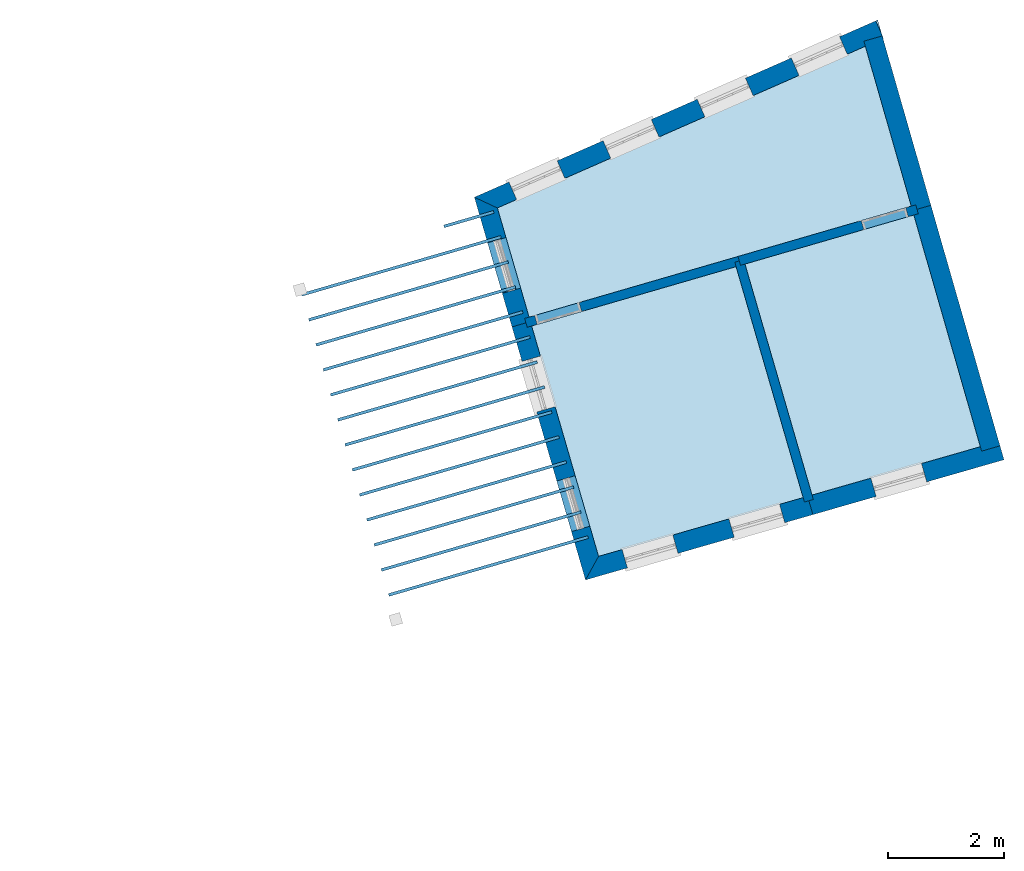
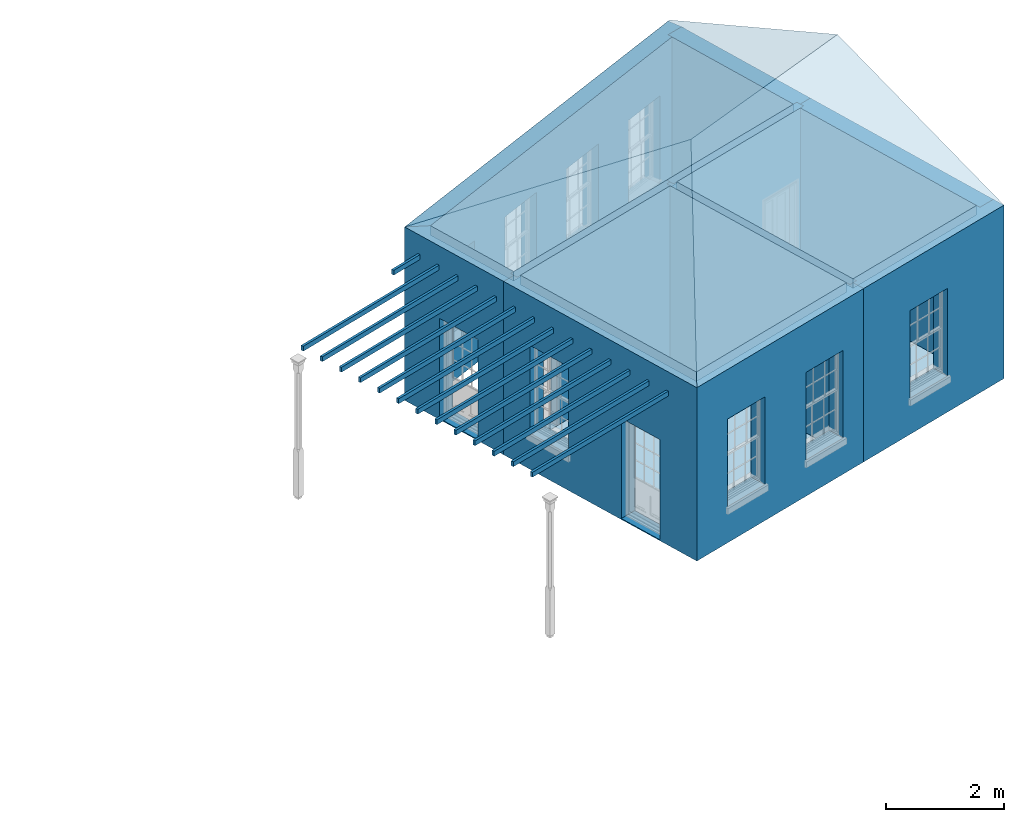
# One storey, part 1 of 10: 19 slabs, 10 walls, 1 roof, 12 openings.
"""IFC2X3 building model written with IfcOpenShell, lengths in metres."""

from ifc_helpers import new_model, si_unit, frame, origin, place, context, subcontext, project, spatial, polyline, outline, extrude, faceted_brep, material, layer, layer_set, layer_usage, element, save


model = new_model("IFC2X3")

# Units and contexts
model_context = context("Model", 3, world=origin())
body_context = subcontext(model_context, "Body", "Model", "MODEL_VIEW")
ifc_project = project(units=[si_unit("PLANEANGLEUNIT", "RADIAN"), si_unit("MASSUNIT", "GRAM", prefix="KILO"), si_unit("FORCEUNIT", "NEWTON", prefix="KILO"), si_unit("LENGTHUNIT", "METRE")], contexts=[model_context])

# Site, building, storey
site_placement = place(None, origin())
site = spatial("IfcSite", under=ifc_project, at=site_placement, CompositionType="ELEMENT")
building_placement = place(None, origin())
building = spatial("IfcBuilding", under=site, at=building_placement, Name="Building plot-15", CompositionType="ELEMENT")
storey_placement = place(None, frame((0.0, 0.0, 11.05)))
storey = spatial("IfcBuildingStorey", under=building, at=storey_placement, Name="Floor 2", CompositionType="ELEMENT", Elevation=11.05)

# Slabs
slab_1_placement = place(storey_placement, frame((0.0, 0.0, 3.4)))
element("IfcSlab", 1, at=slab_1_placement, inside=storey, Name="Slab", ObjectType="Slab", PredefinedType="FLOOR", context=body_context, shape_type="SweptSolid", body=[
    extrude(outline(polyline([(93.1259419481481, 56.4653028026416), (89.5934562606152, 55.4394989093001), (90.7492750995838, 51.4592902821545), (94.2845837491432, 52.4747060086671), (93.1259419481481, 56.4653028026416)])), origin(), (0.0, 0.0, 1.0), 0.2),
])
slab_2_placement = place(storey_placement, frame((0.0, 0.0, 3.1)))
element("IfcSlab", 2, at=slab_2_placement, inside=storey, Name="Slab", ObjectType="Slab", PredefinedType="FLOOR", context=body_context, shape_type="SweptSolid", body=[
    extrude(outline(polyline([(90.5761730497304, 51.7685183951452), (90.5622294870498, 51.816534820041), (87.1161724198014, 50.8158290652416), (87.130115982482, 50.7678126403459), (90.5761730497304, 51.7685183951452)])), origin(), (0.0, 0.0, 1.0), 0.1),
])
slab_3_placement = place(storey_placement, frame((0.0, 0.0, 3.1)))
element("IfcSlab", 3, at=slab_3_placement, inside=storey, Name="Slab", ObjectType="Slab", PredefinedType="FLOOR", context=body_context, shape_type="SweptSolid", body=[
    extrude(outline(polyline([(90.450680985605, 52.2006662192073), (90.4367374229244, 52.248682644103), (86.990680355676, 51.2479768893037), (87.0046239183566, 51.1999604644079), (90.450680985605, 52.2006662192073)])), origin(), (0.0, 0.0, 1.0), 0.1),
])
slab_4_placement = place(storey_placement, frame((0.0, 0.0, 3.1)))
element("IfcSlab", 4, at=slab_4_placement, inside=storey, Name="Slab", ObjectType="Slab", PredefinedType="FLOOR", context=body_context, shape_type="SweptSolid", body=[
    extrude(outline(polyline([(90.3251889214796, 52.6328140432693), (90.311245358799, 52.6808304681651), (86.8651882915506, 51.6801247133657), (86.8791318542312, 51.6321082884699), (90.3251889214796, 52.6328140432693)])), origin(), (0.0, 0.0, 1.0), 0.1),
])
slab_5_placement = place(storey_placement, frame((0.0, 0.0, 3.1)))
element("IfcSlab", 5, at=slab_5_placement, inside=storey, Name="Slab", ObjectType="Slab", PredefinedType="FLOOR", context=body_context, shape_type="SweptSolid", body=[
    extrude(outline(polyline([(90.1996968573542, 53.0649618673313), (90.1857532946736, 53.1129782922271), (86.7396962274252, 52.1122725374277), (86.7536397901058, 52.064256112532), (90.1996968573542, 53.0649618673313)])), origin(), (0.0, 0.0, 1.0), 0.1),
])
slab_6_placement = place(storey_placement, frame((0.0, 0.0, 3.1)))
element("IfcSlab", 6, at=slab_6_placement, inside=storey, Name="Slab", ObjectType="Slab", PredefinedType="FLOOR", context=body_context, shape_type="SweptSolid", body=[
    extrude(outline(polyline([(90.0742047932288, 53.4971096913934), (90.0602612305482, 53.5451261162891), (86.6142041632998, 52.5444203614898), (86.6281477259804, 52.496403936594), (90.0742047932288, 53.4971096913934)])), origin(), (0.0, 0.0, 1.0), 0.1),
])
slab_7_placement = place(storey_placement, frame((0.0, 0.0, 3.1)))
element("IfcSlab", 7, at=slab_7_placement, inside=storey, Name="Slab", ObjectType="Slab", PredefinedType="FLOOR", context=body_context, shape_type="SweptSolid", body=[
    extrude(outline(polyline([(89.9487127291034, 53.9292575154554), (89.9347691664228, 53.9772739403512), (86.4887120991744, 52.9765681855518), (86.502655661855, 52.928551760656), (89.9487127291034, 53.9292575154554)])), origin(), (0.0, 0.0, 1.0), 0.1),
])
slab_8_placement = place(storey_placement, frame((0.0, 0.0, 3.1)))
element("IfcSlab", 8, at=slab_8_placement, inside=storey, Name="Slab", ObjectType="Slab", PredefinedType="FLOOR", context=body_context, shape_type="SweptSolid", body=[
    extrude(outline(polyline([(89.823220664978, 54.3614053395174), (89.8092771022974, 54.4094217644132), (86.363220035049, 53.4087160096138), (86.3771635977296, 53.360699584718), (89.823220664978, 54.3614053395174)])), origin(), (0.0, 0.0, 1.0), 0.1),
])
slab_9_placement = place(storey_placement, frame((0.0, 0.0, 3.1)))
element("IfcSlab", 9, at=slab_9_placement, inside=storey, Name="Slab", ObjectType="Slab", PredefinedType="FLOOR", context=body_context, shape_type="SweptSolid", body=[
    extrude(outline(polyline([(89.6977286008526, 54.7935531635795), (89.683785038172, 54.8415695884752), (86.2377279709236, 53.8408638336759), (86.2516715336042, 53.7928474087801), (89.6977286008526, 54.7935531635795)])), origin(), (0.0, 0.0, 1.0), 0.1),
])
slab_10_placement = place(storey_placement, frame((0.0, 0.0, 3.1)))
element("IfcSlab", 10, at=slab_10_placement, inside=storey, Name="Slab", ObjectType="Slab", PredefinedType="FLOOR", context=body_context, shape_type="SweptSolid", body=[
    extrude(outline(polyline([(89.5722365367273, 55.2257009876415), (89.5582929740467, 55.2737174125373), (86.1122359067982, 54.2730116577379), (86.1261794694788, 54.2249952328421), (89.5722365367273, 55.2257009876415)])), origin(), (0.0, 0.0, 1.0), 0.1),
])
slab_11_placement = place(storey_placement, frame((0.0, 0.0, 3.1)))
element("IfcSlab", 11, at=slab_11_placement, inside=storey, Name="Slab", ObjectType="Slab", PredefinedType="FLOOR", context=body_context, shape_type="SweptSolid", body=[
    extrude(outline(polyline([(89.4467444726019, 55.6578488117035), (89.4328009099213, 55.7058652365993), (85.9867438426728, 54.7051594817999), (86.0006874053534, 54.6571430569041), (89.4467444726019, 55.6578488117035)])), origin(), (0.0, 0.0, 1.0), 0.1),
])
slab_12_placement = place(storey_placement, frame((0.0, 0.0, 3.1)))
element("IfcSlab", 12, at=slab_12_placement, inside=storey, Name="Slab", ObjectType="Slab", PredefinedType="FLOOR", context=body_context, shape_type="SweptSolid", body=[
    extrude(outline(polyline([(89.3212524084765, 56.0899966357656), (89.3073088457959, 56.1380130606613), (85.8612517785474, 55.1373073058619), (85.875195341228, 55.0892908809662), (89.3212524084765, 56.0899966357656)])), origin(), (0.0, 0.0, 1.0), 0.1),
])
slab_13_placement = place(storey_placement, frame((0.0, 0.0, 3.1)))
element("IfcSlab", 13, at=slab_13_placement, inside=storey, Name="Slab", ObjectType="Slab", PredefinedType="FLOOR", context=body_context, shape_type="SweptSolid", body=[
    extrude(outline(polyline([(89.1957603443511, 56.5221444598276), (89.1818167816705, 56.5701608847234), (85.735759714422, 55.569455129924), (85.7497032771026, 55.5214387050282), (89.1957603443511, 56.5221444598276)])), origin(), (0.0, 0.0, 1.0), 0.1),
])
slab_14_placement = place(storey_placement, frame((0.0, 0.0, 3.1)))
element("IfcSlab", 14, at=slab_14_placement, inside=storey, Name="Slab", ObjectType="Slab", PredefinedType="FLOOR", context=body_context, shape_type="SweptSolid", body=[
    extrude(outline(polyline([(89.0702682802257, 56.9542922838896), (89.0563247175451, 57.0023087087854), (85.6102676502966, 56.001602953986), (85.6242112129772, 55.9535865290902), (89.0702682802257, 56.9542922838896)])), origin(), (0.0, 0.0, 1.0), 0.1),
])
slab_15_placement = place(storey_placement, frame((0.0, 0.0, 3.1)))
element("IfcSlab", 15, at=slab_15_placement, inside=storey, Name="Slab", ObjectType="Slab", PredefinedType="FLOOR", context=body_context, shape_type="SweptSolid", body=[
    extrude(outline(polyline([(88.9447762161003, 57.3864401079516), (88.9308326534197, 57.4344565328474), (88.0709453138879, 57.1847525400358), (88.0848888765685, 57.13673611514), (88.9447762161003, 57.3864401079516)])), origin(), (0.0, 0.0, 1.0), 0.1),
])
slab_16_placement = place(storey_placement, frame((0.0, 0.0, 3.4)))
element("IfcSlab", 16, at=slab_16_placement, inside=storey, Name="Slab", ObjectType="Slab", PredefinedType="FLOOR", context=body_context, shape_type="SweptSolid", body=[
    extrude(outline(polyline([(96.1971993792139, 57.357169920847), (93.2795945079686, 56.5099222032643), (94.4383668549021, 52.5188757826638), (97.3469163931548, 53.3542729813922), (96.1971993792139, 57.357169920847)])), origin(), (0.0, 0.0, 1.0), 0.2),
])
slab_17_placement = place(storey_placement, frame((0.0, 0.0, 3.4)))
element("IfcSlab", 17, at=slab_17_placement, inside=storey, Name="Slab", ObjectType="Slab", PredefinedType="FLOOR", context=body_context, shape_type="SweptSolid", body=[
    extrude(outline(polyline([(89.0011789339124, 57.4790809319541), (89.5488368600373, 55.5931514689665), (96.1530295994764, 57.5109530465934), (95.3596374797679, 60.2732561605415), (89.0011789339124, 57.4790809319541)])), origin(), (0.0, 0.0, 1.0), 0.2),
])
slab_18_placement = place(storey_placement, origin())
element("IfcSlab", 18, at=slab_18_placement, inside=storey, Name="Slab", ObjectType="Slab", PredefinedType="FLOOR", context=body_context, shape_type="SweptSolid", body=[
    extrude(outline(polyline([(93.1259419481481, 56.4653028026416), (89.5934562606152, 55.4394989093001), (90.7492750995838, 51.4592902821545), (94.2845837491432, 52.4747060086671), (93.1259419481481, 56.4653028026416)])), origin(), (0.0, 0.0, 1.0), 0.02),
])
slab_19_placement = place(storey_placement, origin())
element("IfcSlab", 19, at=slab_19_placement, inside=storey, Name="Slab", ObjectType="Slab", PredefinedType="FLOOR", context=body_context, shape_type="SweptSolid", body=[
    extrude(outline(polyline([(96.1971993792139, 57.357169920847), (93.2795945079686, 56.5099222032643), (94.4383668549021, 52.5188757826638), (97.3469163931548, 53.3542729813922), (96.1971993792139, 57.357169920847)])), origin(), (0.0, 0.0, 1.0), 0.02),
])

# Wall, openings
ifc_material_1 = material(Name="Masonry")
ifc_layer_1 = layer(ifc_material_1, 0.33, ventilated=False)
ifc_layer_set_1 = layer_set([ifc_layer_1], Name="My Wall")
ifc_layer_usage_1 = layer_usage(ifc_layer_set_1, "AXIS2", "NEGATIVE", 0.08)
wall_1_placement = place(storey_placement, origin())
wall_1 = element("IfcWallStandardCase", 20, at=wall_1_placement, inside=storey, material=ifc_layer_usage_1, Name="exterior", context=body_context, shape_type="SweptSolid", body=[
    extrude(outline(polyline([(95.6723187451732, 60.4106615143609), (95.5395561949644, 60.7127775603797), (88.6036069877965, 57.6648285454347), (89.0011789339124, 57.4790809319541), (95.6723187451732, 60.4106615143609)])), origin(), (0.0, 0.0, 1.0), 3.6),
])
opening_1_placement = place(storey_placement, frame((0.0, 0.0, 0.75)))
element("IfcOpeningElement", 21, at=opening_1_placement, cuts=wall_1, Name="Opening", ObjectType="Opening", context=body_context, shape_type="SweptSolid", body=[
    extrude(outline(polyline([(94.9139268152625, 60.4378495880681), (94.0808189307863, 60.0717467980984), (94.2135814809951, 59.7696307520796), (95.0466893654713, 60.1357335420493), (94.9139268152625, 60.4378495880681)])), origin(), (0.0, 0.0, 1.0), 1.82),
])
opening_2_placement = place(storey_placement, frame((0.0, 0.0, 0.75)))
element("IfcOpeningElement", 22, at=opening_2_placement, cuts=wall_1, Name="Opening", ObjectType="Opening", context=body_context, shape_type="SweptSolid", body=[
    extrude(outline(polyline([(93.2873117562595, 59.7230462325794), (92.4542038717833, 59.3569434426097), (92.5869664219921, 59.0548273965908), (93.4200743064683, 59.4209301865605), (93.2873117562595, 59.7230462325794)])), origin(), (0.0, 0.0, 1.0), 1.82),
])
opening_3_placement = place(storey_placement, frame((0.0, 0.0, 0.75)))
element("IfcOpeningElement", 23, at=opening_3_placement, cuts=wall_1, Name="Opening", ObjectType="Opening", context=body_context, shape_type="SweptSolid", body=[
    extrude(outline(polyline([(91.6606966972566, 59.0082428770907), (90.8275888127803, 58.642140087121), (90.9603513629891, 58.3400240411021), (91.7934592474653, 58.7061268310718), (91.6606966972566, 59.0082428770907)])), origin(), (0.0, 0.0, 1.0), 1.82),
])
opening_4_placement = place(storey_placement, frame((0.0, 0.0, 0.75)))
element("IfcOpeningElement", 24, at=opening_4_placement, cuts=wall_1, Name="Opening", ObjectType="Opening", context=body_context, shape_type="SweptSolid", body=[
    extrude(outline(polyline([(90.0340816382536, 58.2934395216019), (89.2009737537774, 57.9273367316322), (89.3337363039862, 57.6252206856134), (90.1668441884623, 57.9913234755831), (90.0340816382536, 58.2934395216019)])), origin(), (0.0, 0.0, 1.0), 1.82),
])

# Wall, opening
wall_2_placement = place(storey_placement, origin())
wall_2 = element("IfcWallStandardCase", 25, at=wall_2_placement, inside=storey, material=ifc_layer_usage_1, Name="exterior", context=body_context, shape_type="SweptSolid", body=[
    extrude(outline(polyline([(89.0011789339124, 57.4790809319541), (88.6036069877965, 57.6648285454347), (89.2542381560141, 55.4242976754414), (89.5711465603263, 55.5163251891334), (89.0011789339124, 57.4790809319541)])), origin(), (0.0, 0.0, 1.0), 3.6),
])
opening_5_placement = place(storey_placement, frame((0.0, 0.0, 0.0199999999999996)))
element("IfcOpeningElement", 26, at=opening_5_placement, cuts=wall_2, Name="Opening", ObjectType="Opening", context=body_context, shape_type="SweptSolid", body=[
    extrude(outline(polyline([(88.8325905234072, 56.8762947257879), (89.0863633641941, 56.0023957926847), (89.4032717685063, 56.0944233063767), (89.1494989277193, 56.9683222394799), (88.8325905234072, 56.8762947257879)])), origin(), (0.0, 0.0, 1.0), 2.08),
])

# Wall, openings
wall_3_placement = place(storey_placement, origin())
wall_3 = element("IfcWallStandardCase", 27, at=wall_3_placement, inside=storey, material=ifc_layer_usage_1, Name="exterior", context=body_context, shape_type="SweptSolid", body=[
    extrude(outline(polyline([(89.5711465603263, 55.5163251891334), (89.2542381560141, 55.4242976754414), (90.5241253104272, 51.0512803503329), (90.7492750995838, 51.4592902821545), (89.5711465603263, 55.5163251891334)])), origin(), (0.0, 0.0, 1.0), 3.6),
])
opening_6_placement = place(storey_placement, frame((0.0, 0.0, 0.75)))
element("IfcOpeningElement", 28, at=opening_6_placement, cuts=wall_3, Name="Opening", ObjectType="Opening", context=body_context, shape_type="SweptSolid", body=[
    extrude(outline(polyline([(89.4274449986263, 54.8278379656647), (89.6812178394132, 53.9539390325615), (89.9981262437253, 54.0459665462534), (89.7443534029384, 54.9198654793566), (89.4274449986263, 54.8278379656647)])), origin(), (0.0, 0.0, 1.0), 1.82),
])
opening_7_placement = place(storey_placement, frame((0.0, 0.0, 0.0199999999999996)))
element("IfcOpeningElement", 29, at=opening_7_placement, cuts=wall_3, Name="Opening", ObjectType="Opening", context=body_context, shape_type="SweptSolid", body=[
    extrude(outline(polyline([(90.0276315246375, 52.761019613008), (90.2814043654244, 51.8871206799048), (90.5983127697366, 51.9791481935968), (90.3445399289497, 52.8530471267), (90.0276315246375, 52.761019613008)])), origin(), (0.0, 0.0, 1.0), 2.08),
])

wall_4_placement = place(storey_placement, origin())
wall_4 = element("IfcWallStandardCase", 30, at=wall_4_placement, inside=storey, material=ifc_layer_usage_1, Name="exterior", context=body_context, shape_type="SweptSolid", body=[
    extrude(outline(polyline([(90.7492750995838, 51.4592902821545), (90.5241253104272, 51.0512803503329), (94.4527966416063, 52.1796781931848), (94.3616968609291, 52.4968545320888), (90.7492750995838, 51.4592902821545)])), origin(), (0.0, 0.0, 1.0), 3.6),
])
opening_8_placement = place(storey_placement, frame((0.0, 0.0, 0.75)))
element("IfcOpeningElement", 31, at=opening_8_placement, cuts=wall_4, Name="Opening", ObjectType="Opening", context=body_context, shape_type="SweptSolid", body=[
    extrude(outline(polyline([(91.2486615072901, 51.2593825336639), (92.1232992903285, 51.5105970803796), (92.0321995096514, 51.8277734192837), (91.1575617266129, 51.5765588725679), (91.2486615072901, 51.2593825336639)])), origin(), (0.0, 0.0, 1.0), 1.82),
])
opening_9_placement = place(storey_placement, frame((0.0, 0.0, 0.75)))
element("IfcOpeningElement", 32, at=opening_9_placement, cuts=wall_4, Name="Opening", ObjectType="Opening", context=body_context, shape_type="SweptSolid", body=[
    extrude(outline(polyline([(93.0932056691547, 51.7891747911059), (93.9678434521932, 52.0403893378216), (93.876743671516, 52.3575656767257), (93.0021058884776, 52.1063511300099), (93.0932056691547, 51.7891747911059)])), origin(), (0.0, 0.0, 1.0), 1.82),
])

# Wall, opening
wall_5_placement = place(storey_placement, origin())
wall_5 = element("IfcWallStandardCase", 33, at=wall_5_placement, inside=storey, material=ifc_layer_usage_1, Name="exterior", context=body_context, shape_type="SweptSolid", body=[
    extrude(outline(polyline([(94.3616968609291, 52.4968545320888), (94.4527966416063, 52.1796781931848), (97.755192512736, 53.1281964231653), (97.6640927320589, 53.4453727620694), (94.3616968609291, 52.4968545320888)])), origin(), (0.0, 0.0, 1.0), 3.6),
])
opening_10_placement = place(storey_placement, frame((0.0, 0.0, 0.75)))
element("IfcOpeningElement", 34, at=opening_10_placement, cuts=wall_5, Name="Opening", ObjectType="Opening", context=body_context, shape_type="SweptSolid", body=[
    extrude(outline(polyline([(95.5465331330367, 52.4938225421364), (96.4211709160752, 52.7450370888522), (96.3300711353981, 53.0622134277562), (95.4554333523596, 52.8109988810405), (95.5465331330367, 52.4938225421364)])), origin(), (0.0, 0.0, 1.0), 1.82),
])

# Walls
wall_6_placement = place(storey_placement, origin())
element("IfcWallStandardCase", 35, at=wall_6_placement, inside=storey, material=ifc_layer_usage_1, Name="party", context=body_context, shape_type="SweptSolid", body=[
    extrude(outline(polyline([(97.3690011884705, 53.2773817477185), (97.6861775273745, 53.3684815283957), (96.4922262033301, 57.5253862648866), (96.1750498644261, 57.4342864842094), (97.3690011884705, 53.2773817477185)])), origin(), (0.0, 0.0, 1.0), 3.6),
])
wall_7_placement = place(storey_placement, origin())
element("IfcWallStandardCase", 36, at=wall_7_placement, inside=storey, material=ifc_layer_usage_1, Name="party", context=body_context, shape_type="SweptSolid", body=[
    extrude(outline(polyline([(96.1750498644261, 57.4342864842094), (96.4922262033301, 57.5253862648866), (95.6515431973083, 60.4523390637506), (95.3343668584043, 60.3612392830734), (96.1750498644261, 57.4342864842094)])), origin(), (0.0, 0.0, 1.0), 3.6),
])
ifc_material_2 = material(Name="Masonry")
ifc_layer_2 = layer(ifc_material_2, 0.16, ventilated=False)
ifc_layer_set_2 = layer_set([ifc_layer_2], Name="My Wall")
ifc_layer_usage_2 = layer_usage(ifc_layer_set_2, "AXIS2", "NEGATIVE", 0.08)
wall_8_placement = place(storey_placement, origin())
element("IfcWallStandardCase", 37, at=wall_8_placement, inside=storey, material=ifc_layer_usage_2, Name="interior", context=body_context, shape_type="SweptSolid", body=[
    extrude(outline(polyline([(94.3069543779347, 52.397657036795), (94.4606089345549, 52.4422695600352), (93.257289244726, 56.5867460429601), (93.1036346881058, 56.5421335197199), (94.3069543779347, 52.397657036795)])), origin(), (0.0, 0.0, 1.0), 3.6),
])

# Wall, opening
wall_9_placement = place(storey_placement, origin())
wall_9 = element("IfcWallStandardCase", 38, at=wall_9_placement, inside=storey, material=ifc_layer_usage_2, Name="interior", context=body_context, shape_type="SweptSolid", body=[
    extrude(outline(polyline([(93.2027716667049, 56.4876135015068), (93.1581522661269, 56.6412660611732), (89.472010580204, 55.5708417686776), (89.516629980782, 55.4171892090111), (93.2027716667049, 56.4876135015068)])), origin(), (0.0, 0.0, 1.0), 3.6),
])
opening_11_placement = place(storey_placement, frame((0.0, 0.0, 0.0199999999999996)))
element("IfcOpeningElement", 39, at=opening_11_placement, cuts=wall_9, Name="Opening", ObjectType="Opening", context=body_context, shape_type="SweptSolid", body=[
    extrude(outline(polyline([(90.4131325081614, 55.8441355972174), (89.6448697098289, 55.6210385943278), (89.6894891104068, 55.4673860346613), (90.4577519087393, 55.6904830375509), (90.4131325081614, 55.8441355972174)])), origin(), (0.0, 0.0, 1.0), 2.1),
])

wall_10_placement = place(storey_placement, origin())
wall_10 = element("IfcWallStandardCase", 40, at=wall_10_placement, inside=storey, material=ifc_layer_usage_2, Name="interior", context=body_context, shape_type="SweptSolid", body=[
    extrude(outline(polyline([(93.1581522661269, 56.6412660611732), (93.2027716667049, 56.4876135015068), (96.2742507983888, 57.3795449996919), (96.2296313978108, 57.5331975593583), (93.1581522661269, 56.6412660611732)])), origin(), (0.0, 0.0, 1.0), 3.6),
])
opening_12_placement = place(storey_placement, frame((0.0, 0.0, 0.0199999999999996)))
element("IfcOpeningElement", 41, at=opening_12_placement, cuts=wall_10, Name="Opening", ObjectType="Opening", context=body_context, shape_type="SweptSolid", body=[
    extrude(outline(polyline([(95.3331288704315, 57.1062511711521), (96.101391668764, 57.3293481740417), (96.056772268186, 57.4830007337082), (95.2885094698535, 57.2599037308186), (95.3331288704315, 57.1062511711521)])), origin(), (0.0, 0.0, 1.0), 2.1),
])

# Roof
roof_placement = place(building_placement, origin())
element("IfcRoof", 42, at=roof_placement, inside=storey, Name="Roof", ShapeType="FREEFORM", context=body_context, shape_type="Brep", held_by="IfcProductRepresentation", body=[
    faceted_brep([(90.524125, 51.05128, 14.65), (97.755193, 53.128196, 14.65), (96.668822, 56.910545, 16.280043), (93.031949, 55.595885, 16.172522), (95.572573, 60.727286, 14.65), (88.603607, 57.664829, 14.65)], [[[0, 1, 2, 3]], [[4, 5, 3, 2]], [[5, 4, 1, 0]], [[5, 0, 3]], [[1, 4, 2]]]),
])

save(model, "model.ifc")
